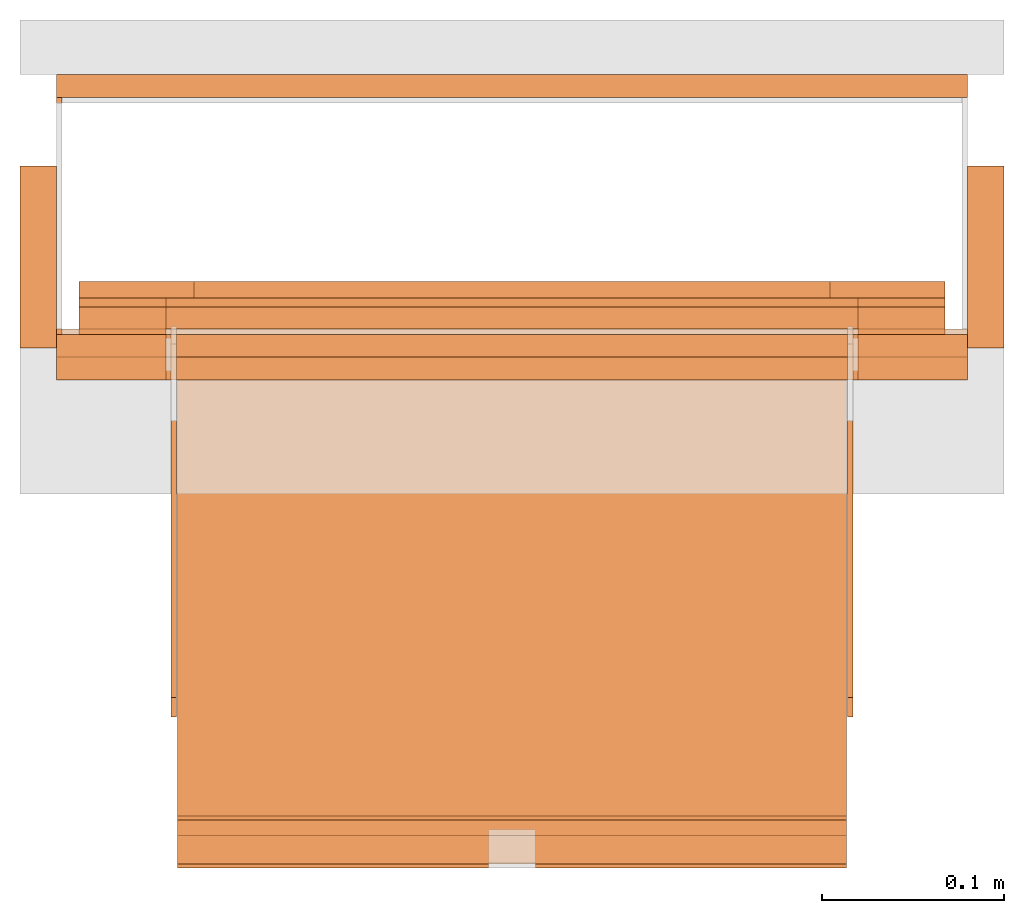
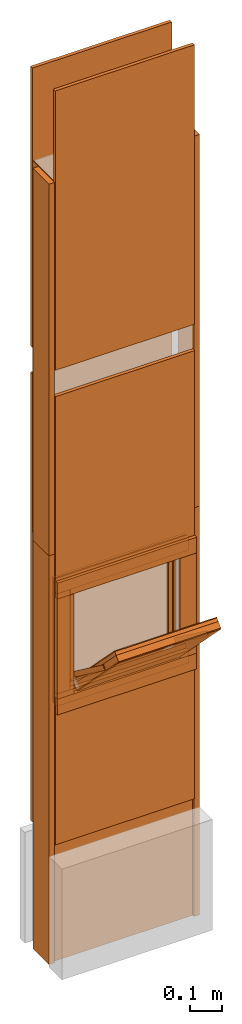
# One storey, part 1 of 3: 32 proxies, 2 openings.
"""IFC2X3 building model written with IfcOpenShell, lengths in metres."""

from ifc_helpers import new_model, entity, si_unit, converted_unit, derived_unit, money_unit, direction, frame, origin_with_axes, origin_2d_with_axis, place, context, subcontext, project, spatial, polyline, rectangle, outline, extrude, faceted_brep, source, transform, mapped, material, type_object, element, save


model = new_model("IFC2X3")

# Units and contexts
model_context = context("Model", 3, precision=1e-05, world=origin_with_axes(), true_north=direction((0.0, 1.0)))
plan_context = context("Plan", 3, precision=1e-05, world=origin_with_axes(), true_north=direction((0.0, 1.0)))
body_context = subcontext(model_context, "Body", "Model", "MODEL_VIEW")
ifc_project = project(units=[si_unit("LENGTHUNIT", "METRE"), si_unit("AREAUNIT", "SQUARE_METRE"), si_unit("VOLUMEUNIT", "CUBIC_METRE"), converted_unit("PLANEANGLEUNIT", "DEGREE", entity("IfcPlaneAngleMeasure", 0.0174532925199), si_unit("PLANEANGLEUNIT", "RADIAN"), dimensions=[0, 0, 0, 0, 0, 0, 0]), si_unit("SOLIDANGLEUNIT", "STERADIAN"), money_unit("CHF"), converted_unit("TIMEUNIT", "Year", entity("IfcTimeMeasure", 31556926.0), si_unit("TIMEUNIT", "SECOND"), dimensions=[0, 0, 1, 0, 0, 0, 0]), si_unit("MASSUNIT", "GRAM", prefix="KILO"), si_unit("THERMODYNAMICTEMPERATUREUNIT", "DEGREE_CELSIUS"), si_unit("LUMINOUSINTENSITYUNIT", "LUMEN"), si_unit("ENERGYUNIT", "JOULE", prefix="MEGA"), derived_unit("THERMALCONDUCTANCEUNIT", [(si_unit("POWERUNIT", "WATT"), 1), (si_unit("LENGTHUNIT", "METRE"), -1), (si_unit("THERMODYNAMICTEMPERATUREUNIT", "KELVIN"), -1)]), derived_unit("SPECIFICHEATCAPACITYUNIT", [(si_unit("ENERGYUNIT", "JOULE"), 1), (si_unit("MASSUNIT", "GRAM", prefix="KILO"), -1), (si_unit("THERMODYNAMICTEMPERATUREUNIT", "KELVIN"), -1)]), derived_unit("MASSDENSITYUNIT", [(si_unit("MASSUNIT", "GRAM", prefix="KILO"), 1), (si_unit("VOLUMEUNIT", "CUBIC_METRE"), -1)])], contexts=[model_context, plan_context])

# Site, building, storey
site_placement = place(None, origin_with_axes())
site = spatial("IfcSite", under=ifc_project, at=site_placement, CompositionType="ELEMENT")
building_placement = place(site_placement, origin_with_axes())
building = spatial("IfcBuilding", under=site, at=building_placement, CompositionType="ELEMENT")
storey_placement = place(building_placement, frame((0.0, 0.0, 2.96), z_axis=(0.0, 0.0, 1.0), x_axis=(1.0, 0.0, 0.0)))
storey = spatial("IfcBuildingStorey", under=building, at=storey_placement, Name="OG01", CompositionType="ELEMENT", Elevation=2.96)

# Proxy
ifc_material_1 = material(Name="Metall, Stahl")
building_element_proxy_type_1 = type_object("IfcBuildingElementProxyType", Name="Metall, Stahl 3", PredefinedType="NOTDEFINED")
proxy_1_placement = place(storey_placement, frame((1.55655524907, -8.09743070606, 1.15), z_axis=(0.0, 0.0, 1.0), x_axis=(0.0, -1.0, 0.0)))
element("IfcBuildingElementProxy", 1, at=proxy_1_placement, inside=storey, type_object=building_element_proxy_type_1, material=ifc_material_1, Name="Wand-005", context=body_context, shape_type="SweptSolid", body=[
    extrude(outline(polyline([(0.0, 0.0), (0.13, 0.0), (0.13, 0.003), (0.0, 0.003), (0.0, 0.0)])), origin_with_axes(), (0.0, 0.0, 1.0), 1.41),
])

# Proxy, opening
proxy_2_placement = place(storey_placement, frame((1.55655524907, -8.22743070606, -0.4), z_axis=(0.0, 0.0, 1.0), x_axis=(1.0, 0.0, 0.0)))
proxy_2 = element("IfcBuildingElementProxy", 2, at=proxy_2_placement, inside=storey, type_object=building_element_proxy_type_1, material=ifc_material_1, Name="Wand-006", context=body_context, shape_type="SweptSolid", body=[
    extrude(outline(polyline([(0.0, 0.0), (0.5, 0.0), (0.5, 0.003), (0.0, 0.003), (0.0, 0.0)])), origin_with_axes(), (0.0, 0.0, 1.0), 1.55),
])
opening_1_placement = place(proxy_2_placement, frame((-1.55655524907, 8.22743070606, -2.56), z_axis=(0.0, 0.0, 1.0), x_axis=(1.0, 0.0, 0.0)))
element("IfcOpeningElement", 3, at=opening_1_placement, cuts=proxy_2, Name="021", context=body_context, shape_type="SweptSolid", body=[
    extrude(rectangle(XDim=0.38, YDim=0.38, at=origin_2d_with_axis()), frame((1.80655524907, -8.25243070606, 3.76), z_axis=(0.0, -1.0, 0.0), x_axis=(1.0, 0.0, 0.0)), (0.0, 0.0, -1.0), 0.031),
])

# Proxies
ifc_material_2 = material(Name="Gipsplatte horizontal")
building_element_proxy_type_2 = type_object("IfcBuildingElementProxyType", Name="Gipsplatte horizontal 13", PredefinedType="NOTDEFINED")
proxy_3_placement = place(storey_placement, frame((1.55655524907, -8.08493070606, 1.85), z_axis=(0.0, 0.0, 1.0), x_axis=(1.0, 0.0, 0.0)))
element("IfcBuildingElementProxy", 4, at=proxy_3_placement, inside=storey, type_object=building_element_proxy_type_2, material=ifc_material_2, Name="Wand-004", context=body_context, shape_type="SweptSolid", body=[
    extrude(outline(polyline([(0.0, -0.0125), (0.5, -0.0125), (0.5, 0.0), (0.0, 0.0), (0.0, -0.0125)])), origin_with_axes(), (0.0, 0.0, 1.0), 1.06),
])
proxy_4_placement = place(storey_placement, frame((1.55655524907, -8.23993070606, 1.85), z_axis=(0.0, 0.0, 1.0), x_axis=(1.0, 0.0, 0.0)))
element("IfcBuildingElementProxy", 5, at=proxy_4_placement, inside=storey, type_object=building_element_proxy_type_2, material=ifc_material_2, Name="Wand-004", context=body_context, shape_type="SweptSolid", body=[
    extrude(outline(polyline([(0.0, 0.0), (0.5, 0.0), (0.5, 0.0125), (0.0, 0.0125), (0.0, 0.0)])), origin_with_axes(), (0.0, 0.0, 1.0), 1.06),
])

# Proxy, opening
proxy_5_placement = place(storey_placement, frame((1.55655524907, -8.23993070606, 0.05), z_axis=(0.0, 0.0, 1.0), x_axis=(1.0, 0.0, 0.0)))
proxy_5 = element("IfcBuildingElementProxy", 6, at=proxy_5_placement, inside=storey, type_object=building_element_proxy_type_2, material=ifc_material_2, Name="Wand-004", context=body_context, shape_type="SweptSolid", body=[
    extrude(outline(polyline([(0.0, 0.0), (0.5, 0.0), (0.5, 0.0125), (0.0, 0.0125), (0.0, 0.0)])), origin_with_axes(), (0.0, 0.0, 1.0), 1.7),
])
opening_2_placement = place(proxy_5_placement, frame((-1.55655524907, 8.23993070606, -3.01), z_axis=(0.0, 0.0, 1.0), x_axis=(1.0, 0.0, 0.0)))
element("IfcOpeningElement", 7, at=opening_2_placement, cuts=proxy_5, Name="020", context=body_context, shape_type="SweptSolid", body=[
    extrude(rectangle(XDim=0.38, YDim=0.38, at=origin_2d_with_axis()), frame((1.80655524907, -8.25243070606, 3.76), z_axis=(0.0, -1.0, 0.0), x_axis=(1.0, 0.0, 0.0)), (0.0, 0.0, -1.0), 0.0375),
])

# Proxies
proxy_6_placement = place(storey_placement, frame((1.55655524907, -8.08493070606, 0.05), z_axis=(0.0, 0.0, 1.0), x_axis=(1.0, 0.0, 0.0)))
element("IfcBuildingElementProxy", 8, at=proxy_6_placement, inside=storey, type_object=building_element_proxy_type_2, material=ifc_material_2, Name="Wand-004", context=body_context, shape_type="SweptSolid", body=[
    extrude(outline(polyline([(0.0, -0.0125), (0.5, -0.0125), (0.5, 0.0), (0.0, 0.0), (0.0, -0.0125)])), origin_with_axes(), (0.0, 0.0, 1.0), 1.7),
])
ifc_material_3 = material(Name="Holz")
building_element_proxy_type_3 = type_object("IfcBuildingElementProxyType", Name="Holz 20", PredefinedType="NOTDEFINED")
proxy_7_placement = place(storey_placement, frame((1.53655524907, -8.13493070606, 1.15), z_axis=(0.0, 0.0, 1.0), x_axis=(0.0, -1.0, 0.0)))
element("IfcBuildingElementProxy", 9, at=proxy_7_placement, inside=storey, type_object=building_element_proxy_type_3, material=ifc_material_3, Name="Wand-004", context=body_context, shape_type="SweptSolid", body=[
    extrude(outline(polyline([(0.0, 0.0), (0.1, 0.0), (0.1, 0.02), (0.0, 0.02), (0.0, 0.0)])), origin_with_axes(), (0.0, 0.0, 1.0), 1.41),
])
proxy_8_placement = place(storey_placement, frame((2.07655524907, -8.13493070606, 1.15), z_axis=(0.0, 0.0, 1.0), x_axis=(0.0, -1.0, 0.0)))
element("IfcBuildingElementProxy", 10, at=proxy_8_placement, inside=storey, type_object=building_element_proxy_type_3, material=ifc_material_3, Name="Wand-003", context=body_context, shape_type="SweptSolid", body=[
    extrude(outline(polyline([(0.0, -0.02), (0.1, -0.02), (0.1, 0.0), (0.0, 0.0), (0.0, -0.02)])), origin_with_axes(), (0.0, 0.0, 1.0), 1.41),
])
proxy_9_placement = place(storey_placement, frame((2.07655524907, -8.13493070606, -0.4), z_axis=(0.0, 0.0, 1.0), x_axis=(0.0, -1.0, 0.0)))
element("IfcBuildingElementProxy", 11, at=proxy_9_placement, inside=storey, type_object=building_element_proxy_type_3, material=ifc_material_3, Name="Wand-003", context=body_context, shape_type="SweptSolid", body=[
    extrude(outline(polyline([(0.0, -0.02), (0.1, -0.02), (0.1, 0.0), (0.0, 0.0), (0.0, -0.02)])), origin_with_axes(), (0.0, 0.0, 1.0), 1.55),
])
proxy_10_placement = place(storey_placement, frame((1.53655524907, -8.13493070606, -0.4), z_axis=(0.0, 0.0, 1.0), x_axis=(0.0, -1.0, 0.0)))
element("IfcBuildingElementProxy", 12, at=proxy_10_placement, inside=storey, type_object=building_element_proxy_type_3, material=ifc_material_3, Name="Wand-004", context=body_context, shape_type="SweptSolid", body=[
    extrude(outline(polyline([(0.0, 0.0), (0.1, 0.0), (0.1, 0.02), (0.0, 0.02), (0.0, 0.0)])), origin_with_axes(), (0.0, 0.0, 1.0), 1.55),
])
building_element_proxy_type_4 = type_object("IfcBuildingElementProxyType", Name="Holz 25", PredefinedType="NOTDEFINED")
for number, where, z_axis, x_axis, name in (
    (13, (2.05655524907, -8.22743070606, 0.99), (0.0, 0.0, 1.0), (-1.0, 0.0, 0.0), "Wand-004"),
    (14, (2.05655524907, -8.22743070606, 0.55), (0.0, 0.0, 1.0), (-1.0, 0.0, 0.0), "Wand-004"),
):
    element("IfcBuildingElementProxy", number, at=place(storey_placement, frame(where, z_axis=z_axis, x_axis=x_axis)), inside=storey, type_object=building_element_proxy_type_4, material=ifc_material_3, Name=name, context=body_context, shape_type="SweptSolid", body=[
        extrude(outline(polyline([(0.0, 0.0), (0.5, 0.0), (0.5, 0.025), (0.0, 0.025), (0.0, 0.0)])), origin_with_axes(), (0.0, 0.0, 1.0), 0.06),
    ])
for number, where, z_axis, x_axis, name in (
    (15, (1.99655524907, -8.25243070606, 0.61), (0.0, 0.0, 1.0), (1.0, 0.0, 0.0), "Wand-004"),
    (16, (1.55655524907, -8.25243070606, 0.61), (0.0, 0.0, 1.0), (1.0, 0.0, 0.0), "Wand-004"),
):
    element("IfcBuildingElementProxy", number, at=place(storey_placement, frame(where, z_axis=z_axis, x_axis=x_axis)), inside=storey, type_object=building_element_proxy_type_4, material=ifc_material_3, Name=name, context=body_context, shape_type="SweptSolid", body=[
        extrude(outline(polyline([(0.0, 0.0), (0.06, 0.0), (0.06, 0.025), (0.0, 0.025), (0.0, 0.0)])), origin_with_axes(), (0.0, 0.0, 1.0), 0.38),
    ])
building_element_proxy_type_5 = type_object("IfcBuildingElementProxyType", Name="Holz 15", PredefinedType="NOTDEFINED")
for number, where, z_axis, x_axis, name in (
    (17, (2.04405524907, -8.21243070606, 0.99), (0.0, 0.0, 1.0), (-1.0, 0.0, 0.0), "Wand-004"),
    (18, (2.04405524907, -8.21243070606, 0.5625), (0.0, 0.0, 1.0), (-1.0, 0.0, 0.0), "Wand-004"),
):
    element("IfcBuildingElementProxy", number, at=place(storey_placement, frame(where, z_axis=z_axis, x_axis=x_axis)), inside=storey, type_object=building_element_proxy_type_5, material=ifc_material_3, Name=name, context=body_context, shape_type="SweptSolid", body=[
        extrude(outline(polyline([(0.0, 0.0), (0.475, 0.0), (0.475, 0.015), (0.0, 0.015), (0.0, 0.0)])), origin_with_axes(), (0.0, 0.0, 1.0), 0.0475),
    ])
for number, where, z_axis, x_axis, name in (
    (19, (1.99655524907, -8.22743070606, 0.61), (0.0, 0.0, 1.0), (1.0, 0.0, 0.0), "Wand-004"),
    (20, (1.56905524907, -8.22743070606, 0.61), (0.0, 0.0, 1.0), (1.0, 0.0, 0.0), "Wand-004"),
):
    element("IfcBuildingElementProxy", number, at=place(storey_placement, frame(where, z_axis=z_axis, x_axis=x_axis)), inside=storey, type_object=building_element_proxy_type_5, material=ifc_material_3, Name=name, context=body_context, shape_type="SweptSolid", body=[
        extrude(outline(polyline([(0.0, 0.0), (0.0475, 0.0), (0.0475, 0.015), (0.0, 0.015), (0.0, 0.0)])), origin_with_axes(), (0.0, 0.0, 1.0), 0.38),
    ])
building_element_proxy_type_6 = type_object("IfcBuildingElementProxyType", Name="Holz 5", PredefinedType="NOTDEFINED")
for number, where, z_axis, x_axis, name in (
    (21, (2.04405524907, -8.21243070606, 1.0), (0.0, 0.0, 1.0), (-1.0, 0.0, 0.0), "Wand-004"),
    (22, (2.04405524907, -8.21243070606, 0.5625), (0.0, 0.0, 1.0), (-1.0, 0.0, 0.0), "Wand-004"),
):
    element("IfcBuildingElementProxy", number, at=place(storey_placement, frame(where, z_axis=z_axis, x_axis=x_axis)), inside=storey, type_object=building_element_proxy_type_6, material=ifc_material_3, Name=name, context=body_context, shape_type="SweptSolid", body=[
        extrude(outline(polyline([(0.0, -0.005), (0.475, -0.005), (0.475, 0.0), (0.0, 0.0), (0.0, -0.005)])), origin_with_axes(), (0.0, 0.0, 1.0), 0.0375),
    ])
for number, where, z_axis, x_axis, name in (
    (23, (1.99655524907, -8.21243070606, 0.6), (0.0, 0.0, 1.0), (1.0, 0.0, 0.0), "Wand-004"),
    (24, (1.56905524907, -8.21243070606, 0.6), (0.0, 0.0, 1.0), (1.0, 0.0, 0.0), "Wand-004"),
):
    element("IfcBuildingElementProxy", number, at=place(storey_placement, frame(where, z_axis=z_axis, x_axis=x_axis)), inside=storey, type_object=building_element_proxy_type_6, material=ifc_material_3, Name=name, context=body_context, shape_type="SweptSolid", body=[
        extrude(outline(polyline([(0.0, 0.0), (0.0475, 0.0), (0.0475, 0.005), (0.0, 0.005), (0.0, 0.0)])), origin_with_axes(), (0.0, 0.0, 1.0), 0.4),
    ])
building_element_proxy_type_7 = type_object("IfcBuildingElementProxyType", Name="Holz 9", PredefinedType="NOTDEFINED")
for number, where, z_axis, x_axis, name in (
    (25, (2.04405524907, -8.20743070606, 0.975), (0.0, 0.0, 1.0), (-1.0, 0.0, 0.0), "Wand-004"),
    (26, (2.04405524907, -8.20743070606, 0.5625), (0.0, 0.0, 1.0), (-1.0, 0.0, 0.0), "Wand-004"),
):
    element("IfcBuildingElementProxy", number, at=place(storey_placement, frame(where, z_axis=z_axis, x_axis=x_axis)), inside=storey, type_object=building_element_proxy_type_7, material=ifc_material_3, Name=name, context=body_context, shape_type="SweptSolid", body=[
        extrude(outline(polyline([(0.0, -0.009), (0.475, -0.009), (0.475, 0.0), (0.0, 0.0), (0.0, -0.009)])), origin_with_axes(), (0.0, 0.0, 1.0), 0.0625),
    ])
for number, where, z_axis, x_axis, name in (
    (27, (1.98105524907, -8.20743070606, 0.625), (0.0, 0.0, 1.0), (1.0, 0.0, 0.0), "Wand-004"),
    (28, (1.56905524907, -8.20743070606, 0.625), (0.0, 0.0, 1.0), (1.0, 0.0, 0.0), "Wand-004"),
):
    element("IfcBuildingElementProxy", number, at=place(storey_placement, frame(where, z_axis=z_axis, x_axis=x_axis)), inside=storey, type_object=building_element_proxy_type_7, material=ifc_material_3, Name=name, context=body_context, shape_type="SweptSolid", body=[
        extrude(outline(polyline([(0.0, 0.0), (0.063, 0.0), (0.063, 0.009), (0.0, 0.009), (0.0, 0.0)])), origin_with_axes(), (0.0, 0.0, 1.0), 0.35),
    ])
ifc_material_4 = material(Name="Metall, Aluminium")
building_element_proxy_type_8 = type_object("IfcBuildingElementProxyType", Name="Metall, Aluminium", PredefinedType="NOTDEFINED")
shared_shape_1 = source(origin_with_axes(), body_context, "Body", "Brep", [
    faceted_brep([(16.1060766769, -3.29167330347, 0.736478855326), (16.1060766769, -3.65867330347, 0.736478855326), (16.1060766769, -3.65867330347, 1.10947885533), (16.1060766769, -3.29167330347, 1.10947885533), (16.1091136769, -3.29167330347, 0.736478855326), (16.1091136769, -3.65867330347, 0.736478855326), (16.1091136769, -3.65867330347, 1.10947885533), (16.1091136769, -3.29167330347, 1.10947885533)], [[[0, 1, 2, 3]], [[1, 0, 4, 5]], [[2, 1, 5, 6]], [[3, 2, 6, 7]], [[0, 3, 7, 4]], [[5, 4, 7, 6]]]),
])
proxy_11_placement = place(storey_placement, frame((5.28172855254, 3.75690888182, 11.375802015), z_axis=(0.0, -0.700249431637, 0.713898265506), x_axis=(0.0, -0.713898265506, -0.700249431637)))
element("IfcBuildingElementProxy", 29, at=proxy_11_placement, inside=storey, type_object=building_element_proxy_type_8, material=ifc_material_4, Name="Wand-004", context=body_context, shape_type="MappedRepresentation", body=[
    mapped(shared_shape_1, transform((0.0, 0.0, 0.0))),
])
building_element_proxy_type_9 = type_object("IfcBuildingElementProxyType", Name="Holz", PredefinedType="NOTDEFINED")
shared_shape_2 = source(origin_with_axes(), body_context, "Body", "Brep", [
    faceted_brep([(16.0840766769, -3.65867330347, 1.10947885533), (16.0840766769, -3.29167330347, 1.10947885533), (16.0840766769, -3.29167330347, 0.736478855326), (16.0840766769, -3.65867330347, 0.736478855326), (16.1060766769, -3.65867330347, 1.10947885533), (16.1060766769, -3.29167330347, 1.10947885533), (16.1060766769, -3.29167330347, 0.736478855326), (16.1060766769, -3.65867330347, 0.736478855326)], [[[0, 1, 2, 3]], [[1, 0, 4, 5]], [[2, 1, 5, 6]], [[3, 2, 6, 7]], [[0, 3, 7, 4]], [[4, 7, 6, 5]]]),
])
proxy_12_placement = place(storey_placement, frame((5.28172855254, 3.75690888182, 11.375802015), z_axis=(0.0, -0.700249431637, 0.713898265506), x_axis=(0.0, -0.713898265506, -0.700249431637)))
element("IfcBuildingElementProxy", 30, at=proxy_12_placement, inside=storey, type_object=building_element_proxy_type_9, material=ifc_material_3, Name="Wand-004", context=body_context, shape_type="MappedRepresentation", body=[
    mapped(shared_shape_2, transform((0.0, 0.0, 0.0))),
])
building_element_proxy_type_10 = type_object("IfcBuildingElementProxyType", Name="Gipsplatte horizontal", PredefinedType="NOTDEFINED")
shared_shape_3 = source(origin_with_axes(), body_context, "Body", "Brep", [
    faceted_brep([(16.0720766769, -3.65867330347, 1.10947885533), (16.0720766769, -3.29167330347, 1.10947885533), (16.0720766769, -3.29167330347, 0.736478855326), (16.0720766769, -3.65867330347, 0.736478855326), (16.0840766769, -3.65867330347, 1.10947885533), (16.0840766769, -3.29167330347, 1.10947885533), (16.0840766769, -3.29167330347, 0.736478855326), (16.0840766769, -3.65867330347, 0.736478855326)], [[[0, 1, 2, 3]], [[1, 0, 4, 5]], [[2, 1, 5, 6]], [[3, 2, 6, 7]], [[0, 3, 7, 4]], [[4, 7, 6, 5]]]),
])
proxy_13_placement = place(storey_placement, frame((5.28172855254, 3.75690888182, 11.375802015), z_axis=(0.0, -0.700249431637, 0.713898265506), x_axis=(0.0, -0.713898265506, -0.700249431637)))
element("IfcBuildingElementProxy", 31, at=proxy_13_placement, inside=storey, type_object=building_element_proxy_type_10, material=ifc_material_2, Name="Wand-004", context=body_context, shape_type="MappedRepresentation", body=[
    mapped(shared_shape_3, transform((0.0, 0.0, 0.0))),
])
shared_shape_4 = source(origin_with_axes(), body_context, "Body", "Brep", [
    faceted_brep([(16.0690396769, -3.29167330347, 0.736478855326), (16.0690396769, -3.65867330347, 0.736478855326), (16.0690396769, -3.65867330347, 1.10947885533), (16.0690396769, -3.29167330347, 1.10947885533), (16.0720766769, -3.29167330347, 0.736478855326), (16.0720766769, -3.65867330347, 0.736478855326), (16.0720766769, -3.65867330347, 1.10947885533), (16.0720766769, -3.29167330347, 1.10947885533)], [[[0, 1, 2, 3]], [[1, 0, 4, 5]], [[2, 1, 5, 6]], [[3, 2, 6, 7]], [[0, 3, 7, 4]], [[5, 4, 7, 6]]]),
])
proxy_14_placement = place(storey_placement, frame((5.28172855254, 3.75690888182, 11.375802015), z_axis=(0.0, -0.700249431637, 0.713898265506), x_axis=(0.0, -0.713898265506, -0.700249431637)))
element("IfcBuildingElementProxy", 32, at=proxy_14_placement, inside=storey, type_object=building_element_proxy_type_8, material=ifc_material_4, Name="Wand-004", context=body_context, shape_type="MappedRepresentation", body=[
    mapped(shared_shape_4, transform((0.0, 0.0, 0.0))),
])
shared_shape_5 = source(origin_with_axes(), body_context, "Body", "Brep", [
    faceted_brep([(16.1152851057, -3.58730556817, 0.89), (16.1152851057, -3.59030556817, 0.89), (16.1152851057, -3.59030556817, 1.14), (16.1152851057, -3.58730556817, 1.14), (16.1332851057, -3.59030556817, 0.89), (16.1332851057, -3.58730556817, 0.89), (16.1332851057, -3.59030556817, 1.14), (16.1332851057, -3.58730556817, 1.14)], [[[0, 1, 2, 3]], [[4, 1, 0, 5]], [[1, 4, 6, 2]], [[2, 6, 7, 3]], [[0, 3, 7, 5]], [[4, 5, 7, 6]]]),
])
for number, where, z_axis, x_axis, name in (
    (33, (5.20986081724, 2.09768488745, 13.081222354), (0.0, -0.80277012101, 0.596288632135), (0.0, -0.596288632135, -0.80277012101), "Wand-004"),
    (34, (5.58086081724, 2.09768488745, 13.081222354), (0.0, -0.80277012101, 0.596288632135), (0.0, -0.596288632135, -0.80277012101), "Wand-004"),
):
    element("IfcBuildingElementProxy", number, at=place(storey_placement, frame(where, z_axis=z_axis, x_axis=x_axis)), inside=storey, type_object=building_element_proxy_type_8, material=ifc_material_4, Name=name, context=body_context, shape_type="MappedRepresentation", body=[
        mapped(shared_shape_5, transform((0.0, 0.0, 0.0))),
    ])

save(model, "model.ifc")
